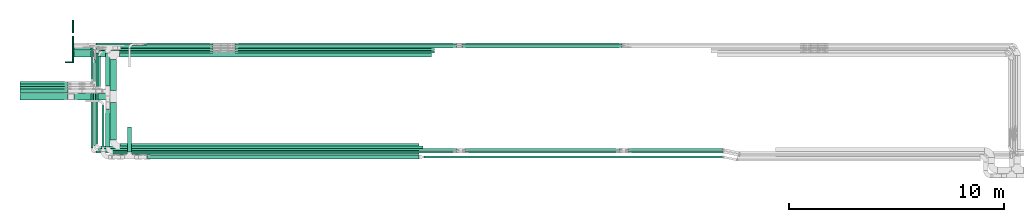
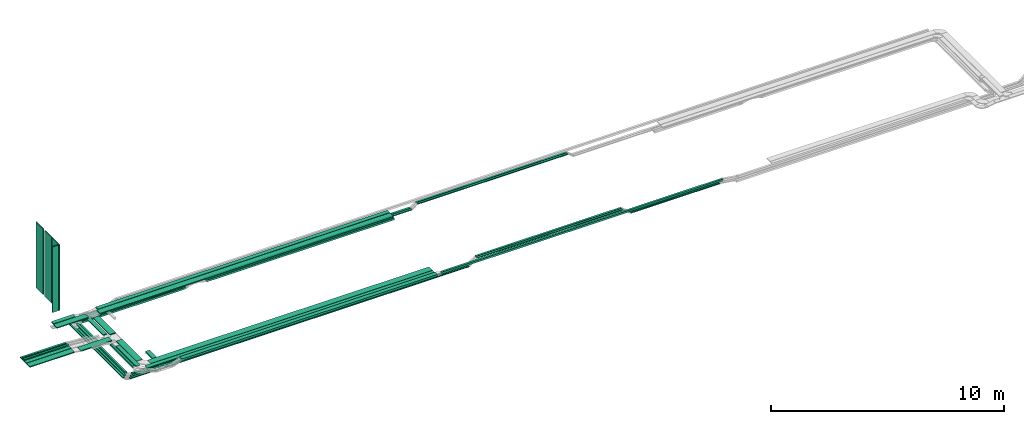
# One storey, part 1 of 19: 47 flow segments.
"""IFC2X3 building model written with IfcOpenShell, lengths in millimetres."""

from ifc_helpers import new_model, entity, si_unit, converted_unit, derived_unit, direction, frame, frame_2d, origin, origin_2d_with_axis, place, context, subcontext, project, spatial, rectangle, extrude, type_object, element, save


model = new_model("IFC2X3")

# Units and contexts
model_context = context("Model", 3, precision=0.01, world=origin(), true_north=direction((6.12303176911189e-17, 1.0)))
body_context = subcontext(model_context, "Body", "Model", "MODEL_VIEW")
ifc_project = project(units=[si_unit("LENGTHUNIT", "METRE", prefix="MILLI"), si_unit("AREAUNIT", "SQUARE_METRE"), si_unit("VOLUMEUNIT", "CUBIC_METRE"), converted_unit("PLANEANGLEUNIT", "DEGREE", entity("IfcRatioMeasure", 0.0174532925199433), si_unit("PLANEANGLEUNIT", "RADIAN"), dimensions=[0, 0, 0, 0, 0, 0, 0]), si_unit("MASSUNIT", "GRAM", prefix="KILO"), derived_unit("MASSDENSITYUNIT", [(si_unit("MASSUNIT", "GRAM", prefix="KILO"), 1), (si_unit("LENGTHUNIT", "METRE"), -3)]), derived_unit("MOMENTOFINERTIAUNIT", [(si_unit("LENGTHUNIT", "METRE"), 4)]), si_unit("TIMEUNIT", "SECOND"), si_unit("FREQUENCYUNIT", "HERTZ"), si_unit("THERMODYNAMICTEMPERATUREUNIT", "DEGREE_CELSIUS"), derived_unit("THERMALTRANSMITTANCEUNIT", [(si_unit("MASSUNIT", "GRAM", prefix="KILO"), 1), (si_unit("THERMODYNAMICTEMPERATUREUNIT", "KELVIN"), -1), (si_unit("TIMEUNIT", "SECOND"), -3)]), derived_unit("VOLUMETRICFLOWRATEUNIT", [(si_unit("LENGTHUNIT", "METRE"), 3), (si_unit("TIMEUNIT", "SECOND"), -1)]), derived_unit("MASSFLOWRATEUNIT", [(si_unit("MASSUNIT", "GRAM", prefix="KILO"), 1), (si_unit("TIMEUNIT", "SECOND"), -1)]), derived_unit("ROTATIONALFREQUENCYUNIT", [(si_unit("TIMEUNIT", "SECOND"), -1)]), si_unit("ELECTRICCURRENTUNIT", "AMPERE"), si_unit("ELECTRICVOLTAGEUNIT", "VOLT"), si_unit("POWERUNIT", "WATT"), si_unit("FORCEUNIT", "NEWTON", prefix="KILO"), si_unit("ILLUMINANCEUNIT", "LUX"), si_unit("LUMINOUSFLUXUNIT", "LUMEN"), si_unit("LUMINOUSINTENSITYUNIT", "CANDELA"), derived_unit("USERDEFINED", [(si_unit("MASSUNIT", "GRAM", prefix="KILO"), -1), (si_unit("LENGTHUNIT", "METRE"), -2), (si_unit("TIMEUNIT", "SECOND"), 3), (si_unit("LUMINOUSFLUXUNIT", "LUMEN"), 1)]), derived_unit("LINEARVELOCITYUNIT", [(si_unit("LENGTHUNIT", "METRE"), 1), (si_unit("TIMEUNIT", "SECOND"), -1)]), si_unit("PRESSUREUNIT", "PASCAL"), derived_unit("USERDEFINED", [(si_unit("LENGTHUNIT", "METRE"), -2), (si_unit("MASSUNIT", "GRAM", prefix="KILO"), 1), (si_unit("TIMEUNIT", "SECOND"), -2)]), derived_unit("LINEARFORCEUNIT", [(si_unit("MASSUNIT", "GRAM", prefix="KILO"), 1), (si_unit("LENGTHUNIT", "METRE"), 1), (si_unit("TIMEUNIT", "SECOND"), -2), (si_unit("LENGTHUNIT", "METRE"), -1)]), derived_unit("PLANARFORCEUNIT", [(si_unit("MASSUNIT", "GRAM", prefix="KILO"), 1), (si_unit("LENGTHUNIT", "METRE"), 1), (si_unit("TIMEUNIT", "SECOND"), -2), (si_unit("LENGTHUNIT", "METRE"), -2)])], contexts=[model_context])

# Site, building, storey
site_placement = place(None, frame((0.0, -0.00077364408347762, 0.0)))
site = spatial("IfcSite", under=ifc_project, at=site_placement, CompositionType="ELEMENT")
building_placement = place(site_placement, origin())
building = spatial("IfcBuilding", under=site, at=building_placement, CompositionType="ELEMENT")
storey_placement = place(building_placement, frame((0.0, 0.0, 12000.0)))
storey = spatial("IfcBuildingStorey", under=building, at=storey_placement, CompositionType="ELEMENT", Elevation=12000.0)

# Flow segments
cable_carrier_segment_type_1 = type_object("IfcCableCarrierSegmentType", PredefinedType="CABLETRAYSEGMENT")
flow_segment_1_placement = place(storey_placement, frame((18658.5368087494, 14255.0, 2800.0)))
element("IfcFlowSegment", 1, at=flow_segment_1_placement, inside=storey, type_object=cable_carrier_segment_type_1, context=body_context, shape_type="SweptSolid", body=[
    extrude(rectangle(XDim=14526.5501481174, YDim=300.000000000001, at=frame_2d((9.09494701772928e-13, 0.0), x_axis=(1.0, 0.0))), frame((7263.27507405872, 150.0, 0.0)), (0.0, 0.0, 1.0), 50.0000000000016),
])
flow_segment_2_placement = place(storey_placement, frame((18739.0712388772, 14572.4967897, 2800.0)))
element("IfcFlowSegment", 2, at=flow_segment_2_placement, inside=storey, type_object=cable_carrier_segment_type_1, context=body_context, shape_type="SweptSolid", body=[
    extrude(rectangle(XDim=14446.0157179897, YDim=200.000000000002, at=frame_2d((-9.09494701772928e-13, 0.0), x_axis=(1.0, 0.0))), frame((7223.00785899482, 100.0, 0.0)), (0.0, 0.0, 1.0), 50.0000000000016),
])
flow_segment_3_placement = place(storey_placement, frame((18679.5368087494, 9924.94245154651, 2800.0)))
element("IfcFlowSegment", 3, at=flow_segment_3_placement, inside=storey, type_object=cable_carrier_segment_type_1, context=body_context, shape_type="SweptSolid", body=[
    extrude(rectangle(XDim=13925.5501481174, YDim=300.000000000001, at=frame_2d((-3.18323145620525e-12, 0.0), x_axis=(1.0, 0.0))), frame((6962.77507405873, 150.0, 0.0)), (0.0, 0.0, 1.0), 50.0000000000016),
])
flow_segment_4_placement = place(storey_placement, frame((18369.5874268759, 9713.17561885418, 2800.80524984479)))
element("IfcFlowSegment", 4, at=flow_segment_4_placement, inside=storey, type_object=cable_carrier_segment_type_1, context=body_context, shape_type="SweptSolid", body=[
    extrude(rectangle(XDim=14235.499529991, YDim=200.000000000001, at=frame_2d((0.0, -5.47117906535277e-13), x_axis=(1.0, 0.0))), frame((7117.74976499548, 100.0, 0.0), z_axis=(0.0, 0.0, 1.0), x_axis=(-1.0, 0.0, 0.0)), (0.0, 0.0, 1.0), 50.0000000000016),
])
flow_segment_5_placement = place(storey_placement, frame((17793.8387136023, 14551.4220205217, 2500.00361418304)))
element("IfcFlowSegment", 5, at=flow_segment_5_placement, inside=storey, type_object=cable_carrier_segment_type_1, context=body_context, shape_type="SweptSolid", body=[
    extrude(rectangle(XDim=5223.92696672905, YDim=99.9999999997434, at=frame_2d((1.13686837721616e-12, 0.0), x_axis=(1.0, 0.0))), frame((2611.96329720162, 50.0, 0.986154857343877), z_axis=(0.000377553079753182, 0.0, 0.999999928726834), x_axis=(0.999999928726834, 0.0, -0.000377553079753182)), (0.0, 0.0, 1.0), 99.9999999997455),
])
flow_segment_6_placement = place(storey_placement, frame((17793.8576157091, 9996.00273150946, 2500.0)))
element("IfcFlowSegment", 6, at=flow_segment_6_placement, inside=storey, type_object=cable_carrier_segment_type_1, context=body_context, shape_type="SweptSolid", body=[
    extrude(rectangle(XDim=14998.1629556795, YDim=99.9999999999989, at=frame_2d((9.09494701772928e-13, 0.0), x_axis=(1.0, 0.0))), frame((7499.08147783974, 50.0, 0.0)), (0.0, 0.0, 1.0), 99.9999999999989),
])
flow_segment_7_placement = place(storey_placement, frame((42335.1102146607, 9888.36195699651, 2500.0)))
element("IfcFlowSegment", 7, at=flow_segment_7_placement, inside=storey, type_object=cable_carrier_segment_type_1, context=body_context, shape_type="SweptSolid", body=[
    extrude(rectangle(XDim=4407.91540658211, YDim=99.9999999999989, at=frame_2d((4.54747350886464e-12, -1.08357767203415e-12), x_axis=(1.0, 0.0))), frame((2203.95770329105, 50.0, 0.0)), (0.0, 0.0, 1.0), 50.0000000000016),
])
flow_segment_8_placement = place(storey_placement, frame((24039.610558903, 14429.9939090692, 2500.0)))
element("IfcFlowSegment", 8, at=flow_segment_8_placement, inside=storey, type_object=cable_carrier_segment_type_1, context=body_context, shape_type="SweptSolid", body=[
    extrude(rectangle(XDim=9279.48815434617, YDim=99.9999999999989, at=frame_2d((0.0, -1.08357767203415e-12), x_axis=(1.0, 0.0))), frame((4639.74407717309, 50.0, 0.0)), (0.0, 0.0, 1.0), 99.9999999999989),
])
flow_segment_9_placement = place(storey_placement, frame((17327.7611527256, 10005.5022288233, 2500.0)))
element("IfcFlowSegment", 9, at=flow_segment_9_placement, inside=storey, type_object=cable_carrier_segment_type_1, context=body_context, shape_type="SweptSolid", body=[
    extrude(rectangle(XDim=3038.65497752374, YDim=99.9999999999989, at=frame_2d((-1.02318153949454e-12, 1.08357767203415e-12), x_axis=(1.0, 0.0))), frame((50.0, 1519.32748876187, 0.0), z_axis=(0.0, 0.0, 1.0), x_axis=(0.0, 1.0, 0.0)), (0.0, 0.0, 1.0), 50.0000000000016),
])
flow_segment_10_placement = place(storey_placement, frame((24036.7268525036, 14792.4967897, 2500.0)))
element("IfcFlowSegment", 10, at=flow_segment_10_placement, inside=storey, type_object=cable_carrier_segment_type_1, context=body_context, shape_type="SweptSolid", body=[
    extrude(rectangle(XDim=10310.0487994365, YDim=99.9999999999989, at=frame_2d((0.0, 1.08357767203415e-12), x_axis=(1.0, 0.0))), frame((5155.02439971824, 50.0, 0.0), z_axis=(0.0, 0.0, 1.0), x_axis=(-1.0, 0.0, 0.0)), (0.0, 0.0, 1.0), 50.0000000000016),
])
flow_segment_11_placement = place(storey_placement, frame((17557.7611527256, 9775.50222882313, 2500.0)))
element("IfcFlowSegment", 11, at=flow_segment_11_placement, inside=storey, type_object=cable_carrier_segment_type_1, context=body_context, shape_type="SweptSolid", body=[
    extrude(rectangle(XDim=16789.0144992146, YDim=99.9999999999989, at=frame_2d((-2.72848410531878e-12, 1.08357767203415e-12), x_axis=(1.0, 0.0))), frame((8394.50724960731, 50.0, 0.0)), (0.0, 0.0, 1.0), 50.0000000000016),
])
flow_segment_12_placement = place(storey_placement, frame((17327.7611527256, 13045.157206347, 2500.0)))
element("IfcFlowSegment", 12, at=flow_segment_12_placement, inside=storey, type_object=cable_carrier_segment_type_1, context=body_context, shape_type="SweptSolid", body=[
    extrude(rectangle(XDim=1617.339583353, YDim=99.9999999999989, at=origin_2d_with_axis()), frame((50.0, 808.669791676503, 0.0), z_axis=(0.0, 0.0, 1.0), x_axis=(0.0, -1.0, 0.0)), (0.0, 0.0, 1.0), 50.0000000000016),
])
flow_segment_13_placement = place(storey_placement, frame((24036.7268525038, 14673.6298749258, 2500.0)))
element("IfcFlowSegment", 13, at=flow_segment_13_placement, inside=storey, type_object=cable_carrier_segment_type_1, context=body_context, shape_type="SweptSolid", body=[
    extrude(rectangle(XDim=10310.0487994361, YDim=99.9999999999989, at=origin_2d_with_axis()), frame((5155.02439971806, 50.0, 0.0), z_axis=(0.0, 0.0, 1.0), x_axis=(-1.0, 0.0, 0.0)), (0.0, 0.0, 1.0), 50.0000000000016),
])
flow_segment_14_placement = place(storey_placement, frame((17450.803072578, 10118.3619569967, 2500.0)))
element("IfcFlowSegment", 14, at=flow_segment_14_placement, inside=storey, type_object=cable_carrier_segment_type_1, context=body_context, shape_type="SweptSolid", body=[
    extrude(rectangle(XDim=2811.07814631135, YDim=99.9999999999989, at=frame_2d((-1.02318153949454e-12, 1.08357767203415e-12), x_axis=(1.0, 0.0))), frame((50.0, 1405.53907315568, 0.0), z_axis=(0.0, 0.0, 1.0), x_axis=(0.0, 1.0, 0.0)), (0.0, 0.0, 1.0), 50.0000000000016),
])
flow_segment_15_placement = place(storey_placement, frame((17563.8386978739, 10225.9780421676, 2499.86227964557)))
element("IfcFlowSegment", 15, at=flow_segment_15_placement, inside=storey, type_object=cable_carrier_segment_type_1, context=body_context, shape_type="SweptSolid", body=[
    extrude(rectangle(XDim=4195.41974263631, YDim=99.9999999999995, at=frame_2d((2.04636307898909e-12, 0.0), x_axis=(1.0, 0.0))), frame((49.9999964363422, 2097.75914529004, 1.0577023745017), z_axis=(0.000377553037651997, -0.000495218459472091, 0.999999806106172), x_axis=(0.0, 0.999999877379314, 0.000495218494767874)), (0.0, 0.0, 1.0), 100.0),
])
flow_segment_16_placement = place(storey_placement, frame((17670.2969319306, 12784.9939090693, 2500.0)))
element("IfcFlowSegment", 16, at=flow_segment_16_placement, inside=storey, type_object=cable_carrier_segment_type_1, context=body_context, shape_type="SweptSolid", body=[
    extrude(rectangle(XDim=1515.00000000002, YDim=99.9999999999989, at=origin_2d_with_axis()), frame((50.0, 757.50000000001, 0.0), z_axis=(0.0, 0.0, 1.0), x_axis=(0.0, -1.0, 0.0)), (0.0, 0.0, 1.0), 99.9999999999989),
])
flow_segment_17_placement = place(storey_placement, frame((18228.5368087494, 10375.9424515465, 2800.0)))
element("IfcFlowSegment", 17, at=flow_segment_17_placement, inside=storey, type_object=cable_carrier_segment_type_1, context=body_context, shape_type="SweptSolid", body=[
    extrude(rectangle(XDim=1743.84857925214, YDim=300.000000000001, at=frame_2d((0.0, 1.08002495835535e-12), x_axis=(1.0, 0.0))), frame((150.0, 871.92428962607, 0.0), z_axis=(0.0, 0.0, 1.0), x_axis=(0.0, -1.0, 0.0)), (0.0, 0.0, 1.0), 50.0000000000016),
])
flow_segment_18_placement = place(storey_placement, frame((16522.305766128, 14255.0, 2800.0)))
element("IfcFlowSegment", 18, at=flow_segment_18_placement, inside=storey, type_object=cable_carrier_segment_type_1, context=body_context, shape_type="SweptSolid", body=[
    extrude(rectangle(XDim=300.000000000001, YDim=1576.23104262143, at=frame_2d((0.0, -2.21689333557151e-12), x_axis=(1.0, 0.0))), frame((788.115521310717, 150.0, 0.0), z_axis=(0.0, 0.0, 1.0), x_axis=(0.0, -1.0, 0.0)), (0.0, 0.0, 1.0), 50.0000000000016),
])
flow_segment_19_placement = place(storey_placement, frame((16550.9424818654, 14572.4967897, 2805.2680783787)))
element("IfcFlowSegment", 19, at=flow_segment_19_placement, inside=storey, type_object=cable_carrier_segment_type_1, context=body_context, shape_type="SweptSolid", body=[
    extrude(rectangle(XDim=1069.99193836187, YDim=200.000000000002, at=frame_2d((2.1600499167107e-12, 0.0), x_axis=(1.0, 0.0))), frame((534.995969180939, 100.0, 0.0), z_axis=(0.0, 0.0, 1.0), x_axis=(-1.0, 0.0, 0.0)), (0.0, 0.0, 1.0), 50.0000000000016),
])
flow_segment_20_placement = place(storey_placement, frame((18018.5874268759, 10064.1756188542, 2800.80524984479)))
element("IfcFlowSegment", 20, at=flow_segment_20_placement, inside=storey, type_object=cable_carrier_segment_type_1, context=body_context, shape_type="SweptSolid", body=[
    extrude(rectangle(XDim=1739.47331484756, YDim=199.999999999998, at=frame_2d((1.08002495835535e-12, 0.0), x_axis=(1.0, 0.0))), frame((100.0, 869.736657423777, 0.0), z_axis=(0.0, 0.0, 1.0), x_axis=(0.0, -1.0, 0.0)), (0.0, 0.0, 1.0), 50.0000000000016),
])
flow_segment_21_placement = place(storey_placement, frame((19026.5152668448, 9817.44715307422, 2628.65031167227)))
element("IfcFlowSegment", 21, at=flow_segment_21_placement, inside=storey, type_object=cable_carrier_segment_type_1, context=body_context, shape_type="SweptSolid", body=[
    extrude(rectangle(XDim=1170.00000000001, YDim=200.000000000002, at=frame_2d((-1.08002495835535e-12, 2.16715534406831e-12), x_axis=(1.0, 0.0))), frame((100.0, 585.0, 0.0), z_axis=(0.0, 0.0, 1.0), x_axis=(0.0, 1.0, 0.0)), (0.0, 0.0, 1.0), 99.9999999999968),
])
flow_segment_22_placement = place(storey_placement, frame((17851.6734101346, 10068.4471530742, 2800.0)))
element("IfcFlowSegment", 22, at=flow_segment_22_placement, inside=storey, type_object=cable_carrier_segment_type_1, context=body_context, shape_type="SweptSolid", body=[
    extrude(rectangle(XDim=1920.94880543369, YDim=99.9999999999989, at=frame_2d((0.0, 1.08357767203415e-12), x_axis=(1.0, 0.0))), frame((50.0, 960.474402716847, 0.0), z_axis=(0.0, 0.0, 1.0), x_axis=(0.0, 1.0, 0.0)), (0.0, 0.0, 1.0), 99.9999999999989),
])
flow_segment_23_placement = place(storey_placement, frame((19963.3435477237, 9487.4471530742, 2800.0)))
element("IfcFlowSegment", 23, at=flow_segment_23_placement, inside=storey, type_object=cable_carrier_segment_type_1, context=body_context, shape_type="SweptSolid", body=[
    extrude(rectangle(XDim=12638.7300000051, YDim=200.0, at=frame_2d((0.0, 5.47117906535277e-13), x_axis=(1.0, 0.0))), frame((6319.36500000254, 100.0, 0.0)), (0.0, 0.0, 1.0), 99.9999999999989),
])
flow_segment_24_placement = place(storey_placement, frame((42335.1102146607, 9775.502228823, 2500.0)))
element("IfcFlowSegment", 24, at=flow_segment_24_placement, inside=storey, type_object=cable_carrier_segment_type_1, context=body_context, shape_type="SweptSolid", body=[
    extrude(rectangle(XDim=4407.9154065821, YDim=99.9999999999989, at=origin_2d_with_axis()), frame((2203.95770329105, 50.0, 0.0)), (0.0, 0.0, 1.0), 50.0000000000016),
])
for number, where in (
    (25, (34752.729143169, 9775.50222882311, 2800.0)),
    (26, (34752.729143169, 9888.36195699659, 2800.0)),
):
    element("IfcFlowSegment", number, at=place(storey_placement, frame(where)), inside=storey, type_object=cable_carrier_segment_type_1, context=body_context, shape_type="SweptSolid", body=[
        extrude(rectangle(XDim=7182.16759799779, YDim=99.9999999999989, at=frame_2d((-2.04636307898909e-12, 1.08357767203415e-12), x_axis=(1.0, 0.0))), frame((3591.0837989989, 50.0, 0.0)), (0.0, 0.0, 1.0), 50.0000000000016),
    ])
flow_segment_25_placement = place(storey_placement, frame((17680.803072578, 9888.36195699661, 2500.0)))
element("IfcFlowSegment", 27, at=flow_segment_25_placement, inside=storey, type_object=cable_carrier_segment_type_1, context=body_context, shape_type="SweptSolid", body=[
    extrude(rectangle(XDim=16665.9725793622, YDim=99.9999999999989, at=frame_2d((-3.63797880709171e-12, 1.08357767203415e-12), x_axis=(1.0, 0.0))), frame((8332.9862896811, 50.0, 0.0)), (0.0, 0.0, 1.0), 50.0000000000016),
])
flow_segment_26_placement = place(storey_placement, frame((34624.7349799484, 14792.4967897, 2700.0)))
element("IfcFlowSegment", 28, at=flow_segment_26_placement, inside=storey, type_object=cable_carrier_segment_type_1, context=body_context, shape_type="SweptSolid", body=[
    extrude(rectangle(XDim=7436.15987018975, YDim=99.9999999999989, at=frame_2d((-2.27373675443232e-12, 0.0), x_axis=(1.0, 0.0))), frame((3718.07993509488, 50.0, 0.0)), (0.0, 0.0, 1.0), 50.0000000000016),
])
flow_segment_27_placement = place(storey_placement, frame((34624.7349799519, 14673.6298749258, 2700.0)))
element("IfcFlowSegment", 29, at=flow_segment_27_placement, inside=storey, type_object=cable_carrier_segment_type_1, context=body_context, shape_type="SweptSolid", body=[
    extrude(rectangle(XDim=7436.15987018413, YDim=99.9999999999989, at=frame_2d((2.04636307898909e-12, 2.16715534406831e-12), x_axis=(1.0, 0.0))), frame((3718.07993509206, 50.0, 0.0)), (0.0, 0.0, 1.0), 50.0000000000016),
])
flow_segment_28_placement = place(storey_placement, frame((18018.5874268759, 12888.7956510923, 2727.85030390842)))
element("IfcFlowSegment", 30, at=flow_segment_28_placement, inside=storey, type_object=cable_carrier_segment_type_1, context=body_context, shape_type="SweptSolid", body=[
    extrude(rectangle(XDim=1553.70113860766, YDim=199.999999999998, at=frame_2d((-1.08002495835535e-12, 0.0), x_axis=(1.0, 0.0))), frame((100.0, 776.850569303832, 0.0), z_axis=(0.0, 0.0, 1.0), x_axis=(0.0, -1.0, 0.0)), (0.0, 0.0, 1.0), 50.0000000000016),
])
flow_segment_29_placement = place(storey_placement, frame((16554.3018310983, 12249.7910307987, 2800.0)))
element("IfcFlowSegment", 31, at=flow_segment_29_placement, inside=storey, type_object=cable_carrier_segment_type_1, context=body_context, shape_type="SweptSolid", body=[
    extrude(rectangle(XDim=1544.23497765111, YDim=300.000000000001, at=frame_2d((1.13686837721616e-12, 0.0), x_axis=(1.0, 0.0))), frame((772.117488825554, 150.0, 0.0), z_axis=(0.0, 0.0, 1.0), x_axis=(-1.0, 0.0, 0.0)), (0.0, 0.0, 1.0), 50.0000000000038),
])
flow_segment_30_placement = place(storey_placement, frame((18228.5368087494, 12679.7910307987, 2800.0)))
element("IfcFlowSegment", 32, at=flow_segment_30_placement, inside=storey, type_object=cable_carrier_segment_type_1, context=body_context, shape_type="SweptSolid", body=[
    extrude(rectangle(XDim=1445.20899434442, YDim=300.000000000001, at=frame_2d((0.0, -1.08002495835535e-12), x_axis=(1.0, 0.0))), frame((150.0, 722.604497172211, 0.0), z_axis=(0.0, 0.0, 1.0), x_axis=(0.0, -1.0, 0.0)), (0.0, 0.0, 1.0), 50.0000000000016),
])
flow_segment_31_placement = place(storey_placement, frame((17557.7611527256, 14792.4967897, 2500.0)))
element("IfcFlowSegment", 33, at=flow_segment_31_placement, inside=storey, type_object=cable_carrier_segment_type_1, context=body_context, shape_type="SweptSolid", body=[
    extrude(rectangle(XDim=5465.06899783628, YDim=99.9999999999989, at=origin_2d_with_axis()), frame((2732.53449891814, 50.0, 0.0)), (0.0, 0.0, 1.0), 50.0000000000016),
])
flow_segment_32_placement = place(storey_placement, frame((17907.2085127223, 14673.6298749258, 2500.0)))
element("IfcFlowSegment", 34, at=flow_segment_32_placement, inside=storey, type_object=cable_carrier_segment_type_1, context=body_context, shape_type="SweptSolid", body=[
    extrude(rectangle(XDim=5115.6216378394, YDim=99.9999999999989, at=frame_2d((-2.27373675443232e-12, -1.08357767203415e-12), x_axis=(1.0, 0.0))), frame((2557.8108189197, 50.0, 0.0)), (0.0, 0.0, 1.0), 50.0000000000016),
])
flow_segment_33_placement = place(storey_placement, frame((24039.610558903, 14551.4220205216, 2500.0)))
element("IfcFlowSegment", 35, at=flow_segment_33_placement, inside=storey, type_object=cable_carrier_segment_type_1, context=body_context, shape_type="SweptSolid", body=[
    extrude(rectangle(XDim=9279.48815434617, YDim=99.9999999999989, at=frame_2d((2.27373675443232e-12, 1.08357767203415e-12), x_axis=(1.0, 0.0))), frame((4639.74407717309, 50.0, 0.0)), (0.0, 0.0, 1.0), 99.9999999999989),
])
flow_segment_34_placement = place(storey_placement, frame((17900.2968546008, 14429.9939090693, 2500.00027830835)))
element("IfcFlowSegment", 36, at=flow_segment_34_placement, inside=storey, type_object=cable_carrier_segment_type_1, context=body_context, shape_type="SweptSolid", body=[
    extrude(rectangle(XDim=5117.52300682955, YDim=99.999999999882, at=frame_2d((-1.13686837721616e-12, 1.08357767203415e-12), x_axis=(1.0, 0.0))), frame((2558.76165807082, 50.0, 0.00395735750659014)), (0.0, 0.0, 1.0), 99.9999999998803),
])
flow_segment_35_placement = place(storey_placement, frame((14029.8171008181, 12249.7910307987, 2850.0)))
element("IfcFlowSegment", 37, at=flow_segment_35_placement, inside=storey, type_object=cable_carrier_segment_type_1, context=body_context, shape_type="SweptSolid", body=[
    extrude(rectangle(XDim=2212.51182941682, YDim=300.000000000001, at=frame_2d((1.02318153949454e-12, -1.08002495835535e-12), x_axis=(1.0, 0.0))), frame((1106.25591470841, 150.0, 0.0), z_axis=(0.0, 0.0, 1.0), x_axis=(-1.0, 0.0, 0.0)), (0.0, 0.0, 1.0), 50.0000000000038),
])
flow_segment_36_placement = place(storey_placement, frame((14029.8171008181, 12994.157206347, 2850.0)))
element("IfcFlowSegment", 38, at=flow_segment_36_placement, inside=storey, type_object=cable_carrier_segment_type_1, context=body_context, shape_type="SweptSolid", body=[
    extrude(rectangle(XDim=2234.42904848946, YDim=99.9999999999989, at=frame_2d((0.0, 2.16715534406831e-12), x_axis=(1.0, 0.0))), frame((1117.21452424473, 50.0, 0.0), z_axis=(0.0, 0.0, 1.0), x_axis=(-1.0, 0.0, 0.0)), (0.0, 0.0, 1.0), 50.0000000000016),
])
flow_segment_37_placement = place(storey_placement, frame((14029.8171008181, 12879.4401033081, 2850.0)))
element("IfcFlowSegment", 39, at=flow_segment_37_placement, inside=storey, type_object=cable_carrier_segment_type_1, context=body_context, shape_type="SweptSolid", body=[
    extrude(rectangle(XDim=2234.42904848907, YDim=99.9999999999989, at=origin_2d_with_axis()), frame((1117.21452424454, 50.0, 0.0), z_axis=(0.0, 0.0, 1.0), x_axis=(-1.0, 0.0, 0.0)), (0.0, 0.0, 1.0), 50.0000000000016),
])
flow_segment_38_placement = place(storey_placement, frame((14029.8171008181, 12558.7956510923, 2850.0)))
element("IfcFlowSegment", 40, at=flow_segment_38_placement, inside=storey, type_object=cable_carrier_segment_type_1, context=body_context, shape_type="SweptSolid", body=[
    extrude(rectangle(XDim=2234.42904848929, YDim=200.000000000002, at=frame_2d((1.13686837721616e-12, 1.08713038571295e-12), x_axis=(1.0, 0.0))), frame((1117.21452424465, 100.0, 0.0), z_axis=(0.0, 0.0, 1.0), x_axis=(-1.0, 0.0, 0.0)), (0.0, 0.0, 1.0), 50.0000000000038),
])
flow_segment_39_placement = place(storey_placement, frame((14029.8171008181, 12764.157206347, 2850.0)))
element("IfcFlowSegment", 41, at=flow_segment_39_placement, inside=storey, type_object=cable_carrier_segment_type_1, context=body_context, shape_type="SweptSolid", body=[
    extrude(rectangle(XDim=2233.4822475641, YDim=99.9999999999989, at=frame_2d((-1.02318153949454e-12, 0.0), x_axis=(1.0, 0.0))), frame((1116.74112378205, 50.0, 0.0), z_axis=(0.0, 0.0, 1.0), x_axis=(-1.0, 0.0, 0.0)), (0.0, 0.0, 1.0), 99.9999999999989),
])
flow_segment_40_placement = place(storey_placement, frame((17450.8030725781, 12930.4401033081, 2500.0)))
element("IfcFlowSegment", 42, at=flow_segment_40_placement, inside=storey, type_object=cable_carrier_segment_type_1, context=body_context, shape_type="SweptSolid", body=[
    extrude(rectangle(XDim=1191.68964176684, YDim=99.9999999999989, at=frame_2d((0.0, 1.08357767203415e-12), x_axis=(1.0, 0.0))), frame((50.0, 595.844820883423, 0.0), z_axis=(0.0, 0.0, 1.0), x_axis=(0.0, 1.0, 0.0)), (0.0, 0.0, 1.0), 50.0000000000016),
])
flow_segment_41_placement = place(storey_placement, frame((32832.0735477288, 9537.44715307416, 2800.0)))
element("IfcFlowSegment", 43, at=flow_segment_41_placement, inside=storey, type_object=cable_carrier_segment_type_1, context=body_context, shape_type="SweptSolid", body=[
    extrude(rectangle(XDim=13917.9501795946, YDim=100.000000000001, at=frame_2d((4.54747350886464e-12, 0.0), x_axis=(1.0, 0.0))), frame((6958.97508979731, 50.0, 0.0)), (0.0, 0.0, 1.0), 99.9999999999989),
])
cable_carrier_segment_type_2 = type_object("IfcCableCarrierSegmentType", PredefinedType="CABLETRAYSEGMENT")
for number, where in (
    (44, (16472.305766128, 15367.6093717678, 3925.84199571755)),
    (45, (16472.305766128, 14607.6093717678, 3925.84199571755)),
):
    element("IfcFlowSegment", number, at=place(storey_placement, frame(where)), inside=storey, type_object=cable_carrier_segment_type_2, context=body_context, shape_type="SweptSolid", body=[
        extrude(rectangle(XDim=50.0000000000016, YDim=600.000000000002, at=origin_2d_with_axis()), frame((25.0, 300.0, 0.0), z_axis=(0.0, 0.0, 1.0), x_axis=(-1.0, 0.0, 0.0)), (0.0, 0.0, 1.0), 3440.0),
    ])
flow_segment_42_placement = place(storey_placement, frame((16472.305766128, 13987.6093717678, 3925.84199571755)))
element("IfcFlowSegment", 46, at=flow_segment_42_placement, inside=storey, type_object=cable_carrier_segment_type_2, context=body_context, shape_type="SweptSolid", body=[
    extrude(rectangle(XDim=50.0000000000016, YDim=599.999999999998, at=frame_2d((0.0, 2.1600499167107e-12), x_axis=(1.0, 0.0))), frame((25.0, 300.0, 0.0), z_axis=(0.0, 0.0, 1.0), x_axis=(-1.0, 0.0, 0.0)), (0.0, 0.0, 1.0), 3440.00000000001),
])
flow_segment_43_placement = place(storey_placement, frame((16147.305766128, 13982.6093717678, 3925.84199571755)))
element("IfcFlowSegment", 47, at=flow_segment_43_placement, inside=storey, type_object=cable_carrier_segment_type_2, context=body_context, shape_type="SweptSolid", body=[
    extrude(rectangle(XDim=50.0000000000016, YDim=300.000000000001, at=origin_2d_with_axis()), frame((150.0, 25.0, 0.0), z_axis=(0.0, 0.0, 1.0), x_axis=(0.0, 1.0, 0.0)), (0.0, 0.0, 1.0), 3440.00000000001),
])

save(model, "model.ifc")
